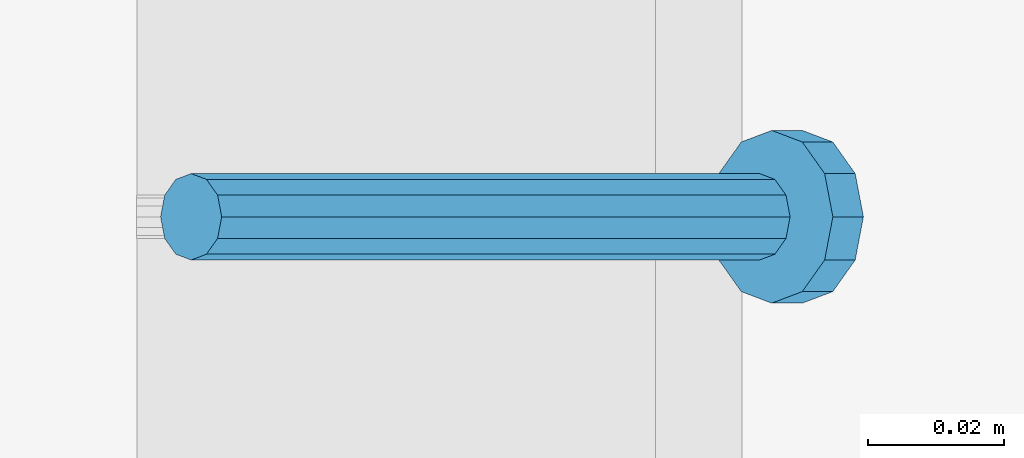
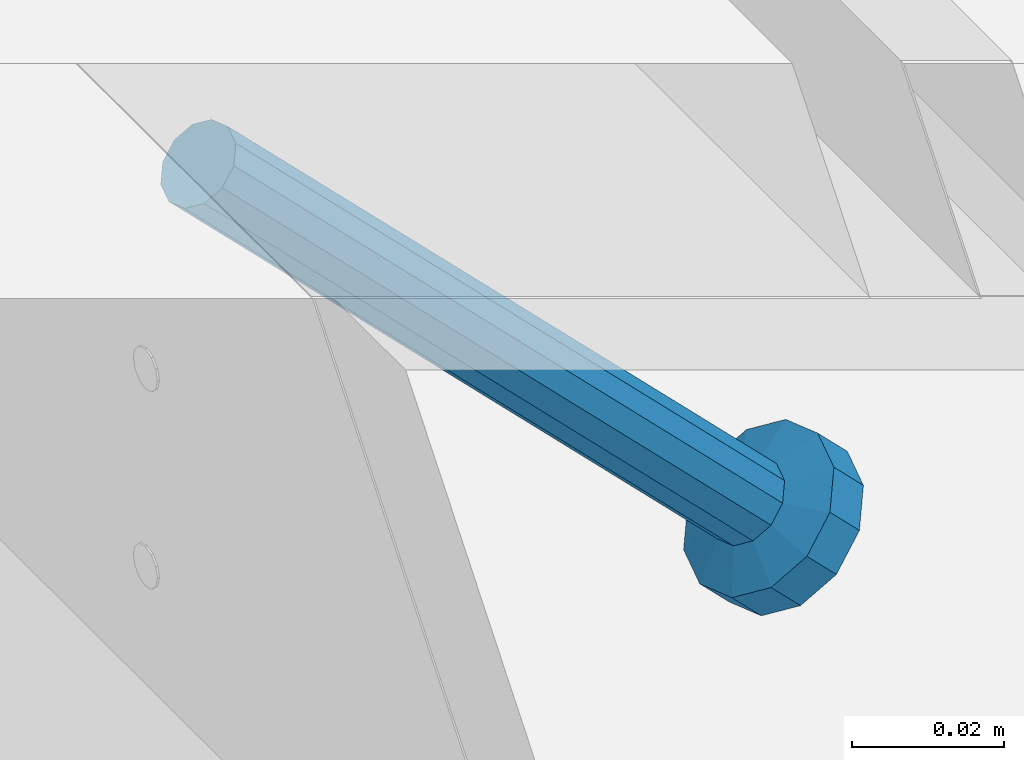
# One storey, part 2240 of 3843: 1 member, 1 element without a shape of its own.
"""IFC2X3 building model written with IfcOpenShell, lengths in millimetres."""

from ifc_helpers import new_model, si_unit, frame, origin_with_axes, place, context, subcontext, project, spatial, faceted_brep, material, type_object, element, aggregate, save


model = new_model("IFC2X3")

# Units and contexts
model_context = context("Model", 3, precision=1e-05, world=origin_with_axes())
body_context = subcontext(model_context, "Body", "Model", "MODEL_VIEW")
ifc_project = project(units=[si_unit("LENGTHUNIT", "METRE", prefix="MILLI"), si_unit("AREAUNIT", "SQUARE_METRE"), si_unit("VOLUMEUNIT", "CUBIC_METRE"), si_unit("MASSUNIT", "GRAM", prefix="KILO"), si_unit("TIMEUNIT", "SECOND"), si_unit("PLANEANGLEUNIT", "RADIAN"), si_unit("SOLIDANGLEUNIT", "STERADIAN"), si_unit("THERMODYNAMICTEMPERATUREUNIT", "DEGREE_CELSIUS"), si_unit("LUMINOUSINTENSITYUNIT", "LUMEN")], contexts=[model_context])

# Site, building, storey
site_placement = place(None, origin_with_axes())
site = spatial("IfcSite", under=ifc_project, at=site_placement, CompositionType="ELEMENT")
building_placement = place(site_placement, origin_with_axes())
building = spatial("IfcBuilding", under=site, at=building_placement, Name="Undefined", CompositionType="ELEMENT")
storey_placement = place(building_placement, origin_with_axes())
storey = spatial("IfcBuildingStorey", under=building, at=storey_placement, Name="Undefined", CompositionType="ELEMENT", Elevation=0.0)

# Assembly, member
assembly_placement = place(storey_placement, origin_with_axes())
assembly = element("IfcElementAssembly", 1, at=assembly_placement, inside=storey, Name="EMBED_ANGLE", AssemblyPlace="NOTDEFINED", PredefinedType="RIGID_FRAME")
ifc_material = material(Name="STEEL/A108")
member_type = type_object("IfcMemberType", PredefinedType="NOTDEFINED")
member_placement = place(assembly_placement, frame((52815.2360419921, 39598.5996154785, 30446.6625), z_axis=(0.0, 1.0, 0.0), x_axis=(0.707106781186548, 0.0, -0.707106781186548)))
member = element("IfcMember", 2, at=member_placement, type_object=member_type, material=ifc_material, Name="HEADED STUD ANCHOR", context=body_context, shape_type="Brep", body=[
    faceted_brep([(7.27595761418343e-12, -3.18000006675175, 5.5), (0.0, -5.49999999998363, 3.1800000667572), (118.110000000976, -5.49999999999091, 3.1800000667572), (118.110000000983, -3.18000006675175, 5.5), (0.0, -6.3499999046162, 0.0), (118.110000000968, -6.34999990461256, 0.0), (0.0, -5.49999999998363, -3.1800000667572), (118.110000000976, -5.49999999999091, -3.1800000667572), (7.27595761418343e-12, -3.18000006675175, -5.5), (118.110000000983, -3.18000006675175, -5.5), (7.27595761418343e-12, -1.81898940354586e-12, -6.34999990463257), (118.110000000968, -1.81898940354586e-12, -6.34999990463257), (0.0, 3.18000006675175, -5.5), (118.110000000968, 3.18000006674811, -5.5), (7.27595761418343e-12, 5.49999999998363, -3.1800000667572), (118.110000000983, 5.49999999998363, -3.1800000667572), (7.27595761418343e-12, 6.3499999046162, 0.0), (118.110000000976, 6.34999990461256, 0.0), (7.27595761418343e-12, 5.49999999998363, 3.1800000667572), (118.110000000983, 5.49999999998363, 3.1800000667572), (0.0, 3.18000006675175, 5.5), (118.110000000968, 3.18000006674811, 5.5), (7.27595761418343e-12, -1.81898940354586e-12, 6.34999990463257), (118.110000000968, -1.81898940354586e-12, 6.34999990463257), (120.650000000991, -10.9899997710909, 6.34999990463257), (120.650000000998, -6.34000015257152, 10.9899997711182), (120.650000000991, -12.6999998092379, 0.0), (120.650000000991, -10.9899997710909, -6.34999990463257), (120.650000000998, -6.34000015257152, -10.9899997711182), (120.650000000991, -1.81898940354586e-12, -12.6899995803833), (120.650000000991, 6.34000015257152, -10.9899997711182), (120.650000000998, 10.9899997710909, -6.34999990463257), (120.650000000991, 12.6999998092342, 0.0), (120.650000000998, 10.9899997710909, 6.34999990463257), (120.650000000991, 6.34000015257152, 10.9899997711182), (120.650000000991, -1.81898940354586e-12, 12.6899995803833), (127.000000001048, -10.9899997710945, 6.34999990463257), (127.000000001048, -6.34000015257152, 10.9899997711182), (127.000000001048, -12.6999998092342, 0.0), (127.000000001048, -10.9899997710945, -6.34999990463257), (127.000000001048, -6.34000015257152, -10.9899997711182), (127.000000001048, 1.81898940354586e-12, -12.6899995803833), (127.000000001048, 6.34000015256788, -10.9899997711182), (127.000000001048, 10.9899997710909, -6.34999990463257), (127.000000001048, 12.6999998092379, 0.0), (127.000000001048, 10.9899997710909, 6.34999990463257), (127.000000001048, 6.34000015256788, 10.9899997711182), (127.000000001048, 1.81898940354586e-12, 12.6899995803833)], [[[0, 1, 2, 3]], [[1, 4, 5, 2]], [[4, 6, 7, 5]], [[6, 8, 9, 7]], [[8, 10, 11, 9]], [[10, 12, 13, 11]], [[12, 14, 15, 13]], [[14, 16, 17, 15]], [[16, 18, 19, 17]], [[18, 20, 21, 19]], [[20, 22, 23, 21]], [[22, 0, 3, 23]], [[22, 20, 18, 16, 14, 12, 10, 8, 6, 4, 1, 0]], [[3, 2, 24, 25]], [[2, 5, 26, 24]], [[5, 7, 27, 26]], [[7, 9, 28, 27]], [[9, 11, 29, 28]], [[11, 13, 30, 29]], [[13, 15, 31, 30]], [[15, 17, 32, 31]], [[17, 19, 33, 32]], [[19, 21, 34, 33]], [[21, 23, 35, 34]], [[23, 3, 25, 35]], [[25, 24, 36, 37]], [[24, 26, 38, 36]], [[26, 27, 39, 38]], [[27, 28, 40, 39]], [[28, 29, 41, 40]], [[29, 30, 42, 41]], [[30, 31, 43, 42]], [[31, 32, 44, 43]], [[32, 33, 45, 44]], [[33, 34, 46, 45]], [[34, 35, 47, 46]], [[35, 25, 37, 47]], [[38, 39, 40, 41, 42, 43, 44, 45, 46, 47, 37, 36]]]),
])
aggregate(assembly, [member])

save(model, "model.ifc")
